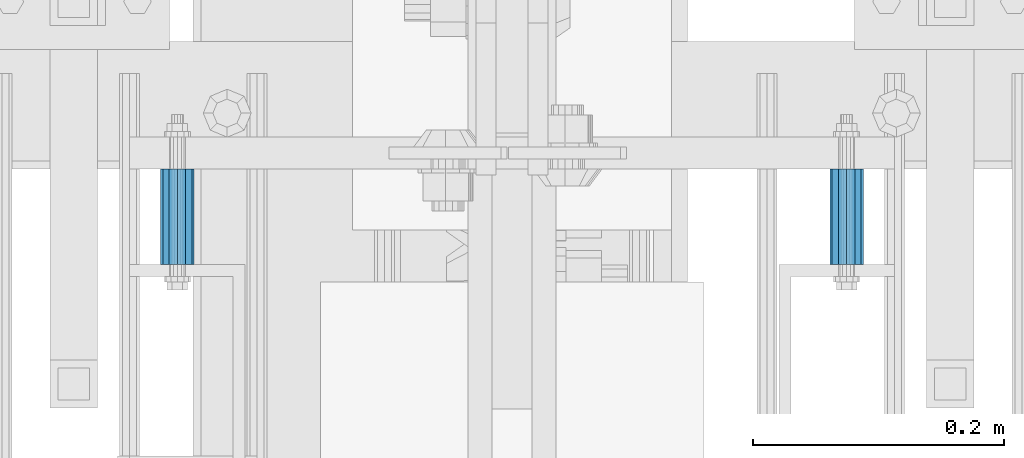
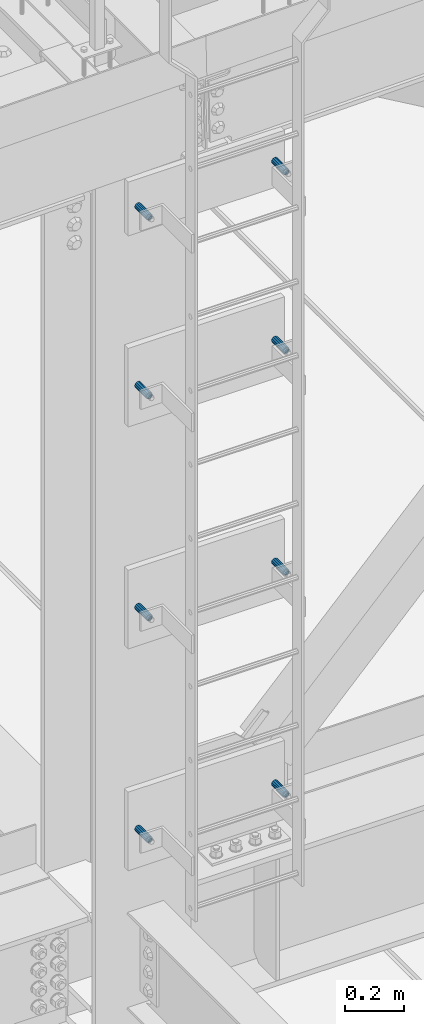
# One storey, part 2821 of 3843: 8 beams, 8 elements without a shape of their own.
"""IFC2X3 building model written with IfcOpenShell, lengths in millimetres."""

from ifc_helpers import new_model, si_unit, frame, origin_with_axes, place, context, subcontext, project, spatial, faceted_brep, material, type_object, element, aggregate, save


model = new_model("IFC2X3")

# Units and contexts
model_context = context("Model", 3, precision=1e-05, world=origin_with_axes())
body_context = subcontext(model_context, "Body", "Model", "MODEL_VIEW")
ifc_project = project(units=[si_unit("LENGTHUNIT", "METRE", prefix="MILLI"), si_unit("AREAUNIT", "SQUARE_METRE"), si_unit("VOLUMEUNIT", "CUBIC_METRE"), si_unit("MASSUNIT", "GRAM", prefix="KILO"), si_unit("TIMEUNIT", "SECOND"), si_unit("PLANEANGLEUNIT", "RADIAN"), si_unit("SOLIDANGLEUNIT", "STERADIAN"), si_unit("THERMODYNAMICTEMPERATUREUNIT", "DEGREE_CELSIUS"), si_unit("LUMINOUSINTENSITYUNIT", "LUMEN")], contexts=[model_context])

# Site, building, storey
site_placement = place(None, origin_with_axes())
site = spatial("IfcSite", under=ifc_project, at=site_placement, CompositionType="ELEMENT")
building_placement = place(site_placement, origin_with_axes())
building = spatial("IfcBuilding", under=site, at=building_placement, Name="Undefined", CompositionType="ELEMENT")
storey_placement = place(building_placement, origin_with_axes())
storey = spatial("IfcBuildingStorey", under=building, at=storey_placement, Name="Undefined", CompositionType="ELEMENT", Elevation=0.0)

# Assembly, beam
assembly_1_placement = place(storey_placement, origin_with_axes())
assembly_1 = element("IfcElementAssembly", 1, at=assembly_1_placement, inside=storey, Name="SLEEVE", AssemblyPlace="NOTDEFINED", PredefinedType="RIGID_FRAME")
ifc_material = material()
beam_type = type_object("IfcBeamType", Name="PIPE3/4SCH40", PredefinedType="NOTDEFINED")
beam_1_placement = place(assembly_1_placement, frame((55664.1000000005, 24930.1000000002, 43132.375), z_axis=(0.0, 0.0, 1.0), x_axis=(0.0, 1.0, 0.0)))
beam_1 = element("IfcBeam", 2, at=beam_1_placement, type_object=beam_type, material=ifc_material, Name="SLEEVE", ObjectType="PIPE3/4SCH40", context=body_context, shape_type="Brep", body=[
    faceted_brep([(0.0, -10.4648000000016, 7.27595761418343e-12), (-7.27595761418343e-12, -9.06278264552384, 5.23240000000806), (76.2000000004009, -9.06278264552384, 5.2324000001172), (76.2000000004045, -10.4648000000016, 1.16415321826935e-10), (-1.45519152283669e-11, -5.23240000000078, 9.06278264553839), (76.20000000039, -5.23240000000078, 9.06278264564753), (-1.45519152283669e-11, 0.0, 10.4648000000161), (76.20000000039, 0.0, 10.4648000001253), (-1.45519152283669e-11, 5.23240000000078, 9.06278264553839), (76.20000000039, 5.23240000000078, 9.06278264564753), (-7.27595761418343e-12, 9.06278264552384, 5.23240000000806), (76.2000000004009, 9.06278264552384, 5.2324000001172), (0.0, 10.4648000000016, 7.27595761418343e-12), (76.2000000004045, 10.4648000000016, 1.16415321826935e-10), (1.09139364212751e-11, 9.06278264552384, -5.2323999999935), (76.2000000004155, 9.06278264552384, -5.23239999988436), (1.45519152283669e-11, 5.23240000000078, -9.06278264551656), (76.2000000004191, 5.23240000000078, -9.06278264540742), (1.45519152283669e-11, 0.0, -10.4647999999943), (76.2000000004191, 0.0, -10.4647999998851), (1.45519152283669e-11, -5.23240000000078, -9.06278264551656), (76.2000000004191, -5.23240000000078, -9.06278264540742), (1.09139364212751e-11, -9.06278264552384, -5.2323999999935), (76.2000000004155, -9.06278264552384, -5.23239999988436), (0.0, -13.3349999999991, 7.27595761418343e-12), (1.09139364212751e-11, -11.5484487594658, -6.66749999999593), (76.2000000004155, -11.5484487594658, -6.66749999988679), (76.2000000004045, -13.3349999999991, 1.16415321826935e-10), (1.45519152283669e-11, -6.66749999999956, -11.5484487594586), (76.2000000004191, -6.66749999999956, -11.5484487593494), (1.81898940354586e-11, 0.0, -13.3349999999919), (76.2000000004227, 0.0, -13.3349999998827), (1.45519152283669e-11, 6.66749999999956, -11.5484487594586), (76.2000000004191, 6.66749999999956, -11.5484487593494), (1.09139364212751e-11, 11.5484487594658, -6.66749999999593), (76.2000000004155, 11.5484487594658, -6.66749999988679), (0.0, 13.3349999999991, 7.27595761418343e-12), (76.2000000004045, 13.3349999999991, 1.16415321826935e-10), (-7.27595761418343e-12, 11.5484487594658, 6.66750000001048), (76.2000000003973, 11.5484487594658, 6.66750000011234), (-1.45519152283669e-11, 6.66749999999956, 11.5484487594804), (76.20000000039, 6.66749999999956, 11.5484487595895), (-1.81898940354586e-11, 0.0, 13.3350000000137), (76.2000000003864, 0.0, 13.3350000001228), (-1.45519152283669e-11, -6.66749999999956, 11.5484487594804), (76.20000000039, -6.66749999999956, 11.5484487595895), (-7.27595761418343e-12, -11.5484487594658, 6.66750000001048), (76.2000000003973, -11.5484487594658, 6.66750000011234)], [[[0, 1, 2, 3]], [[1, 4, 5, 2]], [[4, 6, 7, 5]], [[6, 8, 9, 7]], [[8, 10, 11, 9]], [[10, 12, 13, 11]], [[12, 14, 15, 13]], [[14, 16, 17, 15]], [[16, 18, 19, 17]], [[18, 20, 21, 19]], [[20, 22, 23, 21]], [[22, 0, 3, 23]], [[24, 25, 26, 27]], [[25, 28, 29, 26]], [[28, 30, 31, 29]], [[30, 32, 33, 31]], [[32, 34, 35, 33]], [[34, 36, 37, 35]], [[36, 38, 39, 37]], [[38, 40, 41, 39]], [[40, 42, 43, 41]], [[42, 44, 45, 43]], [[44, 46, 47, 45]], [[46, 24, 27, 47]], [[29, 31, 33, 35, 37, 39, 41, 43, 45, 47, 27, 26], [5, 7, 9, 11, 13, 15, 17, 19, 21, 23, 3, 2]], [[46, 44, 42, 40, 38, 36, 34, 32, 30, 28, 25, 24], [22, 20, 18, 16, 14, 12, 10, 8, 6, 4, 1, 0]]]),
])
aggregate(assembly_1, [beam_1])

assembly_2_placement = place(storey_placement, origin_with_axes())
assembly_2 = element("IfcElementAssembly", 3, at=assembly_2_placement, inside=storey, Name="SLEEVE", AssemblyPlace="NOTDEFINED", PredefinedType="RIGID_FRAME")
beam_2_placement = place(assembly_2_placement, frame((56197.5000000005, 24930.1000000002, 43132.375), z_axis=(0.0, 0.0, 1.0), x_axis=(0.0, 1.0, 0.0)))
beam_2 = element("IfcBeam", 4, at=beam_2_placement, type_object=beam_type, material=ifc_material, Name="SLEEVE", ObjectType="PIPE3/4SCH40", context=body_context, shape_type="Brep", body=[
    faceted_brep([(0.0, -10.4648000000016, 7.27595761418343e-12), (-7.27595761418343e-12, -9.06278264552384, 5.23240000000806), (76.2000000004009, -9.06278264552384, 5.2324000001172), (76.2000000004045, -10.4648000000016, 1.16415321826935e-10), (-1.45519152283669e-11, -5.23240000000078, 9.06278264553839), (76.20000000039, -5.23240000000078, 9.06278264564753), (-1.45519152283669e-11, 0.0, 10.4648000000161), (76.20000000039, 0.0, 10.4648000001253), (-1.45519152283669e-11, 5.23240000000078, 9.06278264553839), (76.20000000039, 5.23240000000078, 9.06278264564753), (-7.27595761418343e-12, 9.06278264552384, 5.23240000000806), (76.2000000004009, 9.06278264552384, 5.2324000001172), (0.0, 10.4648000000016, 7.27595761418343e-12), (76.2000000004045, 10.4648000000016, 1.16415321826935e-10), (1.09139364212751e-11, 9.06278264552384, -5.2323999999935), (76.2000000004155, 9.06278264552384, -5.23239999988436), (1.45519152283669e-11, 5.23240000000078, -9.06278264551656), (76.2000000004191, 5.23240000000078, -9.06278264540742), (1.45519152283669e-11, 0.0, -10.4647999999943), (76.2000000004191, 0.0, -10.4647999998851), (1.45519152283669e-11, -5.23240000000078, -9.06278264551656), (76.2000000004191, -5.23240000000078, -9.06278264540742), (1.09139364212751e-11, -9.06278264552384, -5.2323999999935), (76.2000000004155, -9.06278264552384, -5.23239999988436), (0.0, -13.3349999999991, 7.27595761418343e-12), (1.09139364212751e-11, -11.5484487594658, -6.66749999999593), (76.2000000004155, -11.5484487594658, -6.66749999988679), (76.2000000004045, -13.3349999999991, 1.16415321826935e-10), (1.45519152283669e-11, -6.66749999999956, -11.5484487594586), (76.2000000004191, -6.66749999999956, -11.5484487593494), (1.81898940354586e-11, 0.0, -13.3349999999919), (76.2000000004227, 0.0, -13.3349999998827), (1.45519152283669e-11, 6.66749999999956, -11.5484487594586), (76.2000000004191, 6.66749999999956, -11.5484487593494), (1.09139364212751e-11, 11.5484487594658, -6.66749999999593), (76.2000000004155, 11.5484487594658, -6.66749999988679), (0.0, 13.3349999999991, 7.27595761418343e-12), (76.2000000004045, 13.3349999999991, 1.16415321826935e-10), (-7.27595761418343e-12, 11.5484487594658, 6.66750000001048), (76.2000000003973, 11.5484487594658, 6.66750000011234), (-1.45519152283669e-11, 6.66749999999956, 11.5484487594804), (76.20000000039, 6.66749999999956, 11.5484487595895), (-1.81898940354586e-11, 0.0, 13.3350000000137), (76.2000000003864, 0.0, 13.3350000001228), (-1.45519152283669e-11, -6.66749999999956, 11.5484487594804), (76.20000000039, -6.66749999999956, 11.5484487595895), (-7.27595761418343e-12, -11.5484487594658, 6.66750000001048), (76.2000000003973, -11.5484487594658, 6.66750000011234)], [[[0, 1, 2, 3]], [[1, 4, 5, 2]], [[4, 6, 7, 5]], [[6, 8, 9, 7]], [[8, 10, 11, 9]], [[10, 12, 13, 11]], [[12, 14, 15, 13]], [[14, 16, 17, 15]], [[16, 18, 19, 17]], [[18, 20, 21, 19]], [[20, 22, 23, 21]], [[22, 0, 3, 23]], [[24, 25, 26, 27]], [[25, 28, 29, 26]], [[28, 30, 31, 29]], [[30, 32, 33, 31]], [[32, 34, 35, 33]], [[34, 36, 37, 35]], [[36, 38, 39, 37]], [[38, 40, 41, 39]], [[40, 42, 43, 41]], [[42, 44, 45, 43]], [[44, 46, 47, 45]], [[46, 24, 27, 47]], [[29, 31, 33, 35, 37, 39, 41, 43, 45, 47, 27, 26], [5, 7, 9, 11, 13, 15, 17, 19, 21, 23, 3, 2]], [[46, 44, 42, 40, 38, 36, 34, 32, 30, 28, 25, 24], [22, 20, 18, 16, 14, 12, 10, 8, 6, 4, 1, 0]]]),
])
aggregate(assembly_2, [beam_2])

assembly_3_placement = place(storey_placement, origin_with_axes())
assembly_3 = element("IfcElementAssembly", 5, at=assembly_3_placement, inside=storey, Name="SLEEVE", AssemblyPlace="NOTDEFINED", PredefinedType="RIGID_FRAME")
beam_3_placement = place(assembly_3_placement, frame((55664.1000000005, 24930.1000000002, 44046.775), z_axis=(0.0, 0.0, 1.0), x_axis=(0.0, 1.0, 0.0)))
beam_3 = element("IfcBeam", 6, at=beam_3_placement, type_object=beam_type, material=ifc_material, Name="SLEEVE", ObjectType="PIPE3/4SCH40", context=body_context, shape_type="Brep", body=[
    faceted_brep([(0.0, -10.4648000000016, 7.27595761418343e-12), (-7.27595761418343e-12, -9.06278264552384, 5.23240000000806), (76.2000000004009, -9.06278264552384, 5.2324000001172), (76.2000000004045, -10.4648000000016, 1.16415321826935e-10), (-1.45519152283669e-11, -5.23240000000078, 9.06278264553839), (76.20000000039, -5.23240000000078, 9.06278264564753), (-1.45519152283669e-11, 0.0, 10.4648000000161), (76.20000000039, 0.0, 10.4648000001253), (-1.45519152283669e-11, 5.23240000000078, 9.06278264553839), (76.20000000039, 5.23240000000078, 9.06278264564753), (-7.27595761418343e-12, 9.06278264552384, 5.23240000000806), (76.2000000004009, 9.06278264552384, 5.2324000001172), (0.0, 10.4648000000016, 7.27595761418343e-12), (76.2000000004045, 10.4648000000016, 1.16415321826935e-10), (1.09139364212751e-11, 9.06278264552384, -5.2323999999935), (76.2000000004155, 9.06278264552384, -5.23239999988436), (1.45519152283669e-11, 5.23240000000078, -9.06278264551656), (76.2000000004191, 5.23240000000078, -9.06278264540742), (1.45519152283669e-11, 0.0, -10.4647999999943), (76.2000000004191, 0.0, -10.4647999998851), (1.45519152283669e-11, -5.23240000000078, -9.06278264551656), (76.2000000004191, -5.23240000000078, -9.06278264540742), (1.09139364212751e-11, -9.06278264552384, -5.2323999999935), (76.2000000004155, -9.06278264552384, -5.23239999988436), (0.0, -13.3349999999991, 7.27595761418343e-12), (1.09139364212751e-11, -11.5484487594658, -6.66749999999593), (76.2000000004155, -11.5484487594658, -6.66749999988679), (76.2000000004045, -13.3349999999991, 1.16415321826935e-10), (1.45519152283669e-11, -6.66749999999956, -11.5484487594586), (76.2000000004191, -6.66749999999956, -11.5484487593494), (1.81898940354586e-11, 0.0, -13.3349999999919), (76.2000000004227, 0.0, -13.3349999998827), (1.45519152283669e-11, 6.66749999999956, -11.5484487594586), (76.2000000004191, 6.66749999999956, -11.5484487593494), (1.09139364212751e-11, 11.5484487594658, -6.66749999999593), (76.2000000004155, 11.5484487594658, -6.66749999988679), (0.0, 13.3349999999991, 7.27595761418343e-12), (76.2000000004045, 13.3349999999991, 1.16415321826935e-10), (-7.27595761418343e-12, 11.5484487594658, 6.66750000001048), (76.2000000003973, 11.5484487594658, 6.66750000011234), (-1.45519152283669e-11, 6.66749999999956, 11.5484487594804), (76.20000000039, 6.66749999999956, 11.5484487595895), (-1.81898940354586e-11, 0.0, 13.3350000000137), (76.2000000003864, 0.0, 13.3350000001228), (-1.45519152283669e-11, -6.66749999999956, 11.5484487594804), (76.20000000039, -6.66749999999956, 11.5484487595895), (-7.27595761418343e-12, -11.5484487594658, 6.66750000001048), (76.2000000003973, -11.5484487594658, 6.66750000011234)], [[[0, 1, 2, 3]], [[1, 4, 5, 2]], [[4, 6, 7, 5]], [[6, 8, 9, 7]], [[8, 10, 11, 9]], [[10, 12, 13, 11]], [[12, 14, 15, 13]], [[14, 16, 17, 15]], [[16, 18, 19, 17]], [[18, 20, 21, 19]], [[20, 22, 23, 21]], [[22, 0, 3, 23]], [[24, 25, 26, 27]], [[25, 28, 29, 26]], [[28, 30, 31, 29]], [[30, 32, 33, 31]], [[32, 34, 35, 33]], [[34, 36, 37, 35]], [[36, 38, 39, 37]], [[38, 40, 41, 39]], [[40, 42, 43, 41]], [[42, 44, 45, 43]], [[44, 46, 47, 45]], [[46, 24, 27, 47]], [[29, 31, 33, 35, 37, 39, 41, 43, 45, 47, 27, 26], [5, 7, 9, 11, 13, 15, 17, 19, 21, 23, 3, 2]], [[46, 44, 42, 40, 38, 36, 34, 32, 30, 28, 25, 24], [22, 20, 18, 16, 14, 12, 10, 8, 6, 4, 1, 0]]]),
])
aggregate(assembly_3, [beam_3])

assembly_4_placement = place(storey_placement, origin_with_axes())
assembly_4 = element("IfcElementAssembly", 7, at=assembly_4_placement, inside=storey, Name="SLEEVE", AssemblyPlace="NOTDEFINED", PredefinedType="RIGID_FRAME")
beam_4_placement = place(assembly_4_placement, frame((56197.5000000005, 24930.1000000002, 44046.775), z_axis=(0.0, 0.0, 1.0), x_axis=(0.0, 1.0, 0.0)))
beam_4 = element("IfcBeam", 8, at=beam_4_placement, type_object=beam_type, material=ifc_material, Name="SLEEVE", ObjectType="PIPE3/4SCH40", context=body_context, shape_type="Brep", body=[
    faceted_brep([(0.0, -10.4648000000016, 7.27595761418343e-12), (-7.27595761418343e-12, -9.06278264552384, 5.23240000000806), (76.2000000004009, -9.06278264552384, 5.2324000001172), (76.2000000004045, -10.4648000000016, 1.16415321826935e-10), (-1.45519152283669e-11, -5.23240000000078, 9.06278264553839), (76.20000000039, -5.23240000000078, 9.06278264564753), (-1.45519152283669e-11, 0.0, 10.4648000000161), (76.20000000039, 0.0, 10.4648000001253), (-1.45519152283669e-11, 5.23240000000078, 9.06278264553839), (76.20000000039, 5.23240000000078, 9.06278264564753), (-7.27595761418343e-12, 9.06278264552384, 5.23240000000806), (76.2000000004009, 9.06278264552384, 5.2324000001172), (0.0, 10.4648000000016, 7.27595761418343e-12), (76.2000000004045, 10.4648000000016, 1.16415321826935e-10), (1.09139364212751e-11, 9.06278264552384, -5.2323999999935), (76.2000000004155, 9.06278264552384, -5.23239999988436), (1.45519152283669e-11, 5.23240000000078, -9.06278264551656), (76.2000000004191, 5.23240000000078, -9.06278264540742), (1.45519152283669e-11, 0.0, -10.4647999999943), (76.2000000004191, 0.0, -10.4647999998851), (1.45519152283669e-11, -5.23240000000078, -9.06278264551656), (76.2000000004191, -5.23240000000078, -9.06278264540742), (1.09139364212751e-11, -9.06278264552384, -5.2323999999935), (76.2000000004155, -9.06278264552384, -5.23239999988436), (0.0, -13.3349999999991, 7.27595761418343e-12), (1.09139364212751e-11, -11.5484487594658, -6.66749999999593), (76.2000000004155, -11.5484487594658, -6.66749999988679), (76.2000000004045, -13.3349999999991, 1.16415321826935e-10), (1.45519152283669e-11, -6.66749999999956, -11.5484487594586), (76.2000000004191, -6.66749999999956, -11.5484487593494), (1.81898940354586e-11, 0.0, -13.3349999999919), (76.2000000004227, 0.0, -13.3349999998827), (1.45519152283669e-11, 6.66749999999956, -11.5484487594586), (76.2000000004191, 6.66749999999956, -11.5484487593494), (1.09139364212751e-11, 11.5484487594658, -6.66749999999593), (76.2000000004155, 11.5484487594658, -6.66749999988679), (0.0, 13.3349999999991, 7.27595761418343e-12), (76.2000000004045, 13.3349999999991, 1.16415321826935e-10), (-7.27595761418343e-12, 11.5484487594658, 6.66750000001048), (76.2000000003973, 11.5484487594658, 6.66750000011234), (-1.45519152283669e-11, 6.66749999999956, 11.5484487594804), (76.20000000039, 6.66749999999956, 11.5484487595895), (-1.81898940354586e-11, 0.0, 13.3350000000137), (76.2000000003864, 0.0, 13.3350000001228), (-1.45519152283669e-11, -6.66749999999956, 11.5484487594804), (76.20000000039, -6.66749999999956, 11.5484487595895), (-7.27595761418343e-12, -11.5484487594658, 6.66750000001048), (76.2000000003973, -11.5484487594658, 6.66750000011234)], [[[0, 1, 2, 3]], [[1, 4, 5, 2]], [[4, 6, 7, 5]], [[6, 8, 9, 7]], [[8, 10, 11, 9]], [[10, 12, 13, 11]], [[12, 14, 15, 13]], [[14, 16, 17, 15]], [[16, 18, 19, 17]], [[18, 20, 21, 19]], [[20, 22, 23, 21]], [[22, 0, 3, 23]], [[24, 25, 26, 27]], [[25, 28, 29, 26]], [[28, 30, 31, 29]], [[30, 32, 33, 31]], [[32, 34, 35, 33]], [[34, 36, 37, 35]], [[36, 38, 39, 37]], [[38, 40, 41, 39]], [[40, 42, 43, 41]], [[42, 44, 45, 43]], [[44, 46, 47, 45]], [[46, 24, 27, 47]], [[29, 31, 33, 35, 37, 39, 41, 43, 45, 47, 27, 26], [5, 7, 9, 11, 13, 15, 17, 19, 21, 23, 3, 2]], [[46, 44, 42, 40, 38, 36, 34, 32, 30, 28, 25, 24], [22, 20, 18, 16, 14, 12, 10, 8, 6, 4, 1, 0]]]),
])
aggregate(assembly_4, [beam_4])

assembly_5_placement = place(storey_placement, origin_with_axes())
assembly_5 = element("IfcElementAssembly", 9, at=assembly_5_placement, inside=storey, Name="SLEEVE", AssemblyPlace="NOTDEFINED", PredefinedType="RIGID_FRAME")
beam_5_placement = place(assembly_5_placement, frame((55664.1000000005, 24930.1000000002, 44961.175), z_axis=(0.0, 0.0, 1.0), x_axis=(0.0, 1.0, 0.0)))
beam_5 = element("IfcBeam", 10, at=beam_5_placement, type_object=beam_type, material=ifc_material, Name="SLEEVE", ObjectType="PIPE3/4SCH40", context=body_context, shape_type="Brep", body=[
    faceted_brep([(0.0, -10.4648000000016, 7.27595761418343e-12), (-7.27595761418343e-12, -9.06278264552384, 5.23240000000806), (76.2000000004009, -9.06278264552384, 5.2324000001172), (76.2000000004045, -10.4648000000016, 1.16415321826935e-10), (-1.45519152283669e-11, -5.23240000000078, 9.06278264553839), (76.20000000039, -5.23240000000078, 9.06278264564753), (-1.45519152283669e-11, 0.0, 10.4648000000161), (76.20000000039, 0.0, 10.4648000001253), (-1.45519152283669e-11, 5.23240000000078, 9.06278264553839), (76.20000000039, 5.23240000000078, 9.06278264564753), (-7.27595761418343e-12, 9.06278264552384, 5.23240000000806), (76.2000000004009, 9.06278264552384, 5.2324000001172), (0.0, 10.4648000000016, 7.27595761418343e-12), (76.2000000004045, 10.4648000000016, 1.16415321826935e-10), (1.09139364212751e-11, 9.06278264552384, -5.2323999999935), (76.2000000004155, 9.06278264552384, -5.23239999988436), (1.45519152283669e-11, 5.23240000000078, -9.06278264551656), (76.2000000004191, 5.23240000000078, -9.06278264540742), (1.45519152283669e-11, 0.0, -10.4647999999943), (76.2000000004191, 0.0, -10.4647999998851), (1.45519152283669e-11, -5.23240000000078, -9.06278264551656), (76.2000000004191, -5.23240000000078, -9.06278264540742), (1.09139364212751e-11, -9.06278264552384, -5.2323999999935), (76.2000000004155, -9.06278264552384, -5.23239999988436), (0.0, -13.3349999999991, 7.27595761418343e-12), (1.09139364212751e-11, -11.5484487594658, -6.66749999999593), (76.2000000004155, -11.5484487594658, -6.66749999988679), (76.2000000004045, -13.3349999999991, 1.16415321826935e-10), (1.45519152283669e-11, -6.66749999999956, -11.5484487594586), (76.2000000004191, -6.66749999999956, -11.5484487593494), (1.81898940354586e-11, 0.0, -13.3349999999919), (76.2000000004227, 0.0, -13.3349999998827), (1.45519152283669e-11, 6.66749999999956, -11.5484487594586), (76.2000000004191, 6.66749999999956, -11.5484487593494), (1.09139364212751e-11, 11.5484487594658, -6.66749999999593), (76.2000000004155, 11.5484487594658, -6.66749999988679), (0.0, 13.3349999999991, 7.27595761418343e-12), (76.2000000004045, 13.3349999999991, 1.16415321826935e-10), (-7.27595761418343e-12, 11.5484487594658, 6.66750000001048), (76.2000000003973, 11.5484487594658, 6.66750000011234), (-1.45519152283669e-11, 6.66749999999956, 11.5484487594804), (76.20000000039, 6.66749999999956, 11.5484487595895), (-1.81898940354586e-11, 0.0, 13.3350000000137), (76.2000000003864, 0.0, 13.3350000001228), (-1.45519152283669e-11, -6.66749999999956, 11.5484487594804), (76.20000000039, -6.66749999999956, 11.5484487595895), (-7.27595761418343e-12, -11.5484487594658, 6.66750000001048), (76.2000000003973, -11.5484487594658, 6.66750000011234)], [[[0, 1, 2, 3]], [[1, 4, 5, 2]], [[4, 6, 7, 5]], [[6, 8, 9, 7]], [[8, 10, 11, 9]], [[10, 12, 13, 11]], [[12, 14, 15, 13]], [[14, 16, 17, 15]], [[16, 18, 19, 17]], [[18, 20, 21, 19]], [[20, 22, 23, 21]], [[22, 0, 3, 23]], [[24, 25, 26, 27]], [[25, 28, 29, 26]], [[28, 30, 31, 29]], [[30, 32, 33, 31]], [[32, 34, 35, 33]], [[34, 36, 37, 35]], [[36, 38, 39, 37]], [[38, 40, 41, 39]], [[40, 42, 43, 41]], [[42, 44, 45, 43]], [[44, 46, 47, 45]], [[46, 24, 27, 47]], [[29, 31, 33, 35, 37, 39, 41, 43, 45, 47, 27, 26], [5, 7, 9, 11, 13, 15, 17, 19, 21, 23, 3, 2]], [[46, 44, 42, 40, 38, 36, 34, 32, 30, 28, 25, 24], [22, 20, 18, 16, 14, 12, 10, 8, 6, 4, 1, 0]]]),
])
aggregate(assembly_5, [beam_5])

assembly_6_placement = place(storey_placement, origin_with_axes())
assembly_6 = element("IfcElementAssembly", 11, at=assembly_6_placement, inside=storey, Name="SLEEVE", AssemblyPlace="NOTDEFINED", PredefinedType="RIGID_FRAME")
beam_6_placement = place(assembly_6_placement, frame((56197.5000000005, 24930.1000000002, 44961.175), z_axis=(0.0, 0.0, 1.0), x_axis=(0.0, 1.0, 0.0)))
beam_6 = element("IfcBeam", 12, at=beam_6_placement, type_object=beam_type, material=ifc_material, Name="SLEEVE", ObjectType="PIPE3/4SCH40", context=body_context, shape_type="Brep", body=[
    faceted_brep([(0.0, -10.4648000000016, 7.27595761418343e-12), (-7.27595761418343e-12, -9.06278264552384, 5.23240000000806), (76.2000000004009, -9.06278264552384, 5.2324000001172), (76.2000000004045, -10.4648000000016, 1.16415321826935e-10), (-1.45519152283669e-11, -5.23240000000078, 9.06278264553839), (76.20000000039, -5.23240000000078, 9.06278264564753), (-1.45519152283669e-11, 0.0, 10.4648000000161), (76.20000000039, 0.0, 10.4648000001253), (-1.45519152283669e-11, 5.23240000000078, 9.06278264553839), (76.20000000039, 5.23240000000078, 9.06278264564753), (-7.27595761418343e-12, 9.06278264552384, 5.23240000000806), (76.2000000004009, 9.06278264552384, 5.2324000001172), (0.0, 10.4648000000016, 7.27595761418343e-12), (76.2000000004045, 10.4648000000016, 1.16415321826935e-10), (1.09139364212751e-11, 9.06278264552384, -5.2323999999935), (76.2000000004155, 9.06278264552384, -5.23239999988436), (1.45519152283669e-11, 5.23240000000078, -9.06278264551656), (76.2000000004191, 5.23240000000078, -9.06278264540742), (1.45519152283669e-11, 0.0, -10.4647999999943), (76.2000000004191, 0.0, -10.4647999998851), (1.45519152283669e-11, -5.23240000000078, -9.06278264551656), (76.2000000004191, -5.23240000000078, -9.06278264540742), (1.09139364212751e-11, -9.06278264552384, -5.2323999999935), (76.2000000004155, -9.06278264552384, -5.23239999988436), (0.0, -13.3349999999991, 7.27595761418343e-12), (1.09139364212751e-11, -11.5484487594658, -6.66749999999593), (76.2000000004155, -11.5484487594658, -6.66749999988679), (76.2000000004045, -13.3349999999991, 1.16415321826935e-10), (1.45519152283669e-11, -6.66749999999956, -11.5484487594586), (76.2000000004191, -6.66749999999956, -11.5484487593494), (1.81898940354586e-11, 0.0, -13.3349999999919), (76.2000000004227, 0.0, -13.3349999998827), (1.45519152283669e-11, 6.66749999999956, -11.5484487594586), (76.2000000004191, 6.66749999999956, -11.5484487593494), (1.09139364212751e-11, 11.5484487594658, -6.66749999999593), (76.2000000004155, 11.5484487594658, -6.66749999988679), (0.0, 13.3349999999991, 7.27595761418343e-12), (76.2000000004045, 13.3349999999991, 1.16415321826935e-10), (-7.27595761418343e-12, 11.5484487594658, 6.66750000001048), (76.2000000003973, 11.5484487594658, 6.66750000011234), (-1.45519152283669e-11, 6.66749999999956, 11.5484487594804), (76.20000000039, 6.66749999999956, 11.5484487595895), (-1.81898940354586e-11, 0.0, 13.3350000000137), (76.2000000003864, 0.0, 13.3350000001228), (-1.45519152283669e-11, -6.66749999999956, 11.5484487594804), (76.20000000039, -6.66749999999956, 11.5484487595895), (-7.27595761418343e-12, -11.5484487594658, 6.66750000001048), (76.2000000003973, -11.5484487594658, 6.66750000011234)], [[[0, 1, 2, 3]], [[1, 4, 5, 2]], [[4, 6, 7, 5]], [[6, 8, 9, 7]], [[8, 10, 11, 9]], [[10, 12, 13, 11]], [[12, 14, 15, 13]], [[14, 16, 17, 15]], [[16, 18, 19, 17]], [[18, 20, 21, 19]], [[20, 22, 23, 21]], [[22, 0, 3, 23]], [[24, 25, 26, 27]], [[25, 28, 29, 26]], [[28, 30, 31, 29]], [[30, 32, 33, 31]], [[32, 34, 35, 33]], [[34, 36, 37, 35]], [[36, 38, 39, 37]], [[38, 40, 41, 39]], [[40, 42, 43, 41]], [[42, 44, 45, 43]], [[44, 46, 47, 45]], [[46, 24, 27, 47]], [[29, 31, 33, 35, 37, 39, 41, 43, 45, 47, 27, 26], [5, 7, 9, 11, 13, 15, 17, 19, 21, 23, 3, 2]], [[46, 44, 42, 40, 38, 36, 34, 32, 30, 28, 25, 24], [22, 20, 18, 16, 14, 12, 10, 8, 6, 4, 1, 0]]]),
])
aggregate(assembly_6, [beam_6])

assembly_7_placement = place(storey_placement, origin_with_axes())
assembly_7 = element("IfcElementAssembly", 13, at=assembly_7_placement, inside=storey, Name="SLEEVE", AssemblyPlace="NOTDEFINED", PredefinedType="RIGID_FRAME")
beam_7_placement = place(assembly_7_placement, frame((55664.1000000005, 24930.1000000003, 45697.775), z_axis=(0.0, 0.0, 1.0), x_axis=(0.0, 1.0, 0.0)))
beam_7 = element("IfcBeam", 14, at=beam_7_placement, type_object=beam_type, material=ifc_material, Name="SLEEVE", ObjectType="PIPE3/4SCH40", context=body_context, shape_type="Brep", body=[
    faceted_brep([(0.0, -10.4648000000016, 7.27595761418343e-12), (-7.27595761418343e-12, -9.06278264552384, 5.23240000000806), (76.2000000004009, -9.06278264552384, 5.2324000001172), (76.2000000004045, -10.4648000000016, 1.16415321826935e-10), (-1.45519152283669e-11, -5.23240000000078, 9.06278264553839), (76.20000000039, -5.23240000000078, 9.06278264564753), (-1.45519152283669e-11, 0.0, 10.4648000000161), (76.20000000039, 0.0, 10.4648000001253), (-1.45519152283669e-11, 5.23240000000078, 9.06278264553839), (76.20000000039, 5.23240000000078, 9.06278264564753), (-7.27595761418343e-12, 9.06278264552384, 5.23240000000806), (76.2000000004009, 9.06278264552384, 5.2324000001172), (0.0, 10.4648000000016, 7.27595761418343e-12), (76.2000000004045, 10.4648000000016, 1.16415321826935e-10), (1.09139364212751e-11, 9.06278264552384, -5.2323999999935), (76.2000000004155, 9.06278264552384, -5.23239999988436), (1.45519152283669e-11, 5.23240000000078, -9.06278264551656), (76.2000000004191, 5.23240000000078, -9.06278264540742), (1.45519152283669e-11, 0.0, -10.4647999999943), (76.2000000004191, 0.0, -10.4647999998851), (1.45519152283669e-11, -5.23240000000078, -9.06278264551656), (76.2000000004191, -5.23240000000078, -9.06278264540742), (1.09139364212751e-11, -9.06278264552384, -5.2323999999935), (76.2000000004155, -9.06278264552384, -5.23239999988436), (0.0, -13.3349999999991, 7.27595761418343e-12), (1.09139364212751e-11, -11.5484487594658, -6.66749999999593), (76.2000000004155, -11.5484487594658, -6.66749999988679), (76.2000000004045, -13.3349999999991, 1.16415321826935e-10), (1.45519152283669e-11, -6.66749999999956, -11.5484487594586), (76.2000000004191, -6.66749999999956, -11.5484487593494), (1.81898940354586e-11, 0.0, -13.3349999999919), (76.2000000004227, 0.0, -13.3349999998827), (1.45519152283669e-11, 6.66749999999956, -11.5484487594586), (76.2000000004191, 6.66749999999956, -11.5484487593494), (1.09139364212751e-11, 11.5484487594658, -6.66749999999593), (76.2000000004155, 11.5484487594658, -6.66749999988679), (0.0, 13.3349999999991, 7.27595761418343e-12), (76.2000000004045, 13.3349999999991, 1.16415321826935e-10), (-7.27595761418343e-12, 11.5484487594658, 6.66750000001048), (76.2000000003973, 11.5484487594658, 6.66750000011234), (-1.45519152283669e-11, 6.66749999999956, 11.5484487594804), (76.20000000039, 6.66749999999956, 11.5484487595895), (-1.81898940354586e-11, 0.0, 13.3350000000137), (76.2000000003864, 0.0, 13.3350000001228), (-1.45519152283669e-11, -6.66749999999956, 11.5484487594804), (76.20000000039, -6.66749999999956, 11.5484487595895), (-7.27595761418343e-12, -11.5484487594658, 6.66750000001048), (76.2000000003973, -11.5484487594658, 6.66750000011234)], [[[0, 1, 2, 3]], [[1, 4, 5, 2]], [[4, 6, 7, 5]], [[6, 8, 9, 7]], [[8, 10, 11, 9]], [[10, 12, 13, 11]], [[12, 14, 15, 13]], [[14, 16, 17, 15]], [[16, 18, 19, 17]], [[18, 20, 21, 19]], [[20, 22, 23, 21]], [[22, 0, 3, 23]], [[24, 25, 26, 27]], [[25, 28, 29, 26]], [[28, 30, 31, 29]], [[30, 32, 33, 31]], [[32, 34, 35, 33]], [[34, 36, 37, 35]], [[36, 38, 39, 37]], [[38, 40, 41, 39]], [[40, 42, 43, 41]], [[42, 44, 45, 43]], [[44, 46, 47, 45]], [[46, 24, 27, 47]], [[29, 31, 33, 35, 37, 39, 41, 43, 45, 47, 27, 26], [5, 7, 9, 11, 13, 15, 17, 19, 21, 23, 3, 2]], [[46, 44, 42, 40, 38, 36, 34, 32, 30, 28, 25, 24], [22, 20, 18, 16, 14, 12, 10, 8, 6, 4, 1, 0]]]),
])
aggregate(assembly_7, [beam_7])

assembly_8_placement = place(storey_placement, origin_with_axes())
assembly_8 = element("IfcElementAssembly", 15, at=assembly_8_placement, inside=storey, Name="SLEEVE", AssemblyPlace="NOTDEFINED", PredefinedType="RIGID_FRAME")
beam_8_placement = place(assembly_8_placement, frame((56197.5000000005, 24930.1000000003, 45697.775), z_axis=(0.0, 0.0, 1.0), x_axis=(0.0, 1.0, 0.0)))
beam_8 = element("IfcBeam", 16, at=beam_8_placement, type_object=beam_type, material=ifc_material, Name="SLEEVE", ObjectType="PIPE3/4SCH40", context=body_context, shape_type="Brep", body=[
    faceted_brep([(0.0, -10.4648000000016, 7.27595761418343e-12), (-7.27595761418343e-12, -9.06278264552384, 5.23240000000806), (76.2000000004009, -9.06278264552384, 5.2324000001172), (76.2000000004045, -10.4648000000016, 1.16415321826935e-10), (-1.45519152283669e-11, -5.23240000000078, 9.06278264553839), (76.20000000039, -5.23240000000078, 9.06278264564753), (-1.45519152283669e-11, 0.0, 10.4648000000161), (76.20000000039, 0.0, 10.4648000001253), (-1.45519152283669e-11, 5.23240000000078, 9.06278264553839), (76.20000000039, 5.23240000000078, 9.06278264564753), (-7.27595761418343e-12, 9.06278264552384, 5.23240000000806), (76.2000000004009, 9.06278264552384, 5.2324000001172), (0.0, 10.4648000000016, 7.27595761418343e-12), (76.2000000004045, 10.4648000000016, 1.16415321826935e-10), (1.09139364212751e-11, 9.06278264552384, -5.2323999999935), (76.2000000004155, 9.06278264552384, -5.23239999988436), (1.45519152283669e-11, 5.23240000000078, -9.06278264551656), (76.2000000004191, 5.23240000000078, -9.06278264540742), (1.45519152283669e-11, 0.0, -10.4647999999943), (76.2000000004191, 0.0, -10.4647999998851), (1.45519152283669e-11, -5.23240000000078, -9.06278264551656), (76.2000000004191, -5.23240000000078, -9.06278264540742), (1.09139364212751e-11, -9.06278264552384, -5.2323999999935), (76.2000000004155, -9.06278264552384, -5.23239999988436), (0.0, -13.3349999999991, 7.27595761418343e-12), (1.09139364212751e-11, -11.5484487594658, -6.66749999999593), (76.2000000004155, -11.5484487594658, -6.66749999988679), (76.2000000004045, -13.3349999999991, 1.16415321826935e-10), (1.45519152283669e-11, -6.66749999999956, -11.5484487594586), (76.2000000004191, -6.66749999999956, -11.5484487593494), (1.81898940354586e-11, 0.0, -13.3349999999919), (76.2000000004227, 0.0, -13.3349999998827), (1.45519152283669e-11, 6.66749999999956, -11.5484487594586), (76.2000000004191, 6.66749999999956, -11.5484487593494), (1.09139364212751e-11, 11.5484487594658, -6.66749999999593), (76.2000000004155, 11.5484487594658, -6.66749999988679), (0.0, 13.3349999999991, 7.27595761418343e-12), (76.2000000004045, 13.3349999999991, 1.16415321826935e-10), (-7.27595761418343e-12, 11.5484487594658, 6.66750000001048), (76.2000000003973, 11.5484487594658, 6.66750000011234), (-1.45519152283669e-11, 6.66749999999956, 11.5484487594804), (76.20000000039, 6.66749999999956, 11.5484487595895), (-1.81898940354586e-11, 0.0, 13.3350000000137), (76.2000000003864, 0.0, 13.3350000001228), (-1.45519152283669e-11, -6.66749999999956, 11.5484487594804), (76.20000000039, -6.66749999999956, 11.5484487595895), (-7.27595761418343e-12, -11.5484487594658, 6.66750000001048), (76.2000000003973, -11.5484487594658, 6.66750000011234)], [[[0, 1, 2, 3]], [[1, 4, 5, 2]], [[4, 6, 7, 5]], [[6, 8, 9, 7]], [[8, 10, 11, 9]], [[10, 12, 13, 11]], [[12, 14, 15, 13]], [[14, 16, 17, 15]], [[16, 18, 19, 17]], [[18, 20, 21, 19]], [[20, 22, 23, 21]], [[22, 0, 3, 23]], [[24, 25, 26, 27]], [[25, 28, 29, 26]], [[28, 30, 31, 29]], [[30, 32, 33, 31]], [[32, 34, 35, 33]], [[34, 36, 37, 35]], [[36, 38, 39, 37]], [[38, 40, 41, 39]], [[40, 42, 43, 41]], [[42, 44, 45, 43]], [[44, 46, 47, 45]], [[46, 24, 27, 47]], [[29, 31, 33, 35, 37, 39, 41, 43, 45, 47, 27, 26], [5, 7, 9, 11, 13, 15, 17, 19, 21, 23, 3, 2]], [[46, 44, 42, 40, 38, 36, 34, 32, 30, 28, 25, 24], [22, 20, 18, 16, 14, 12, 10, 8, 6, 4, 1, 0]]]),
])
aggregate(assembly_8, [beam_8])

save(model, "model.ifc")
